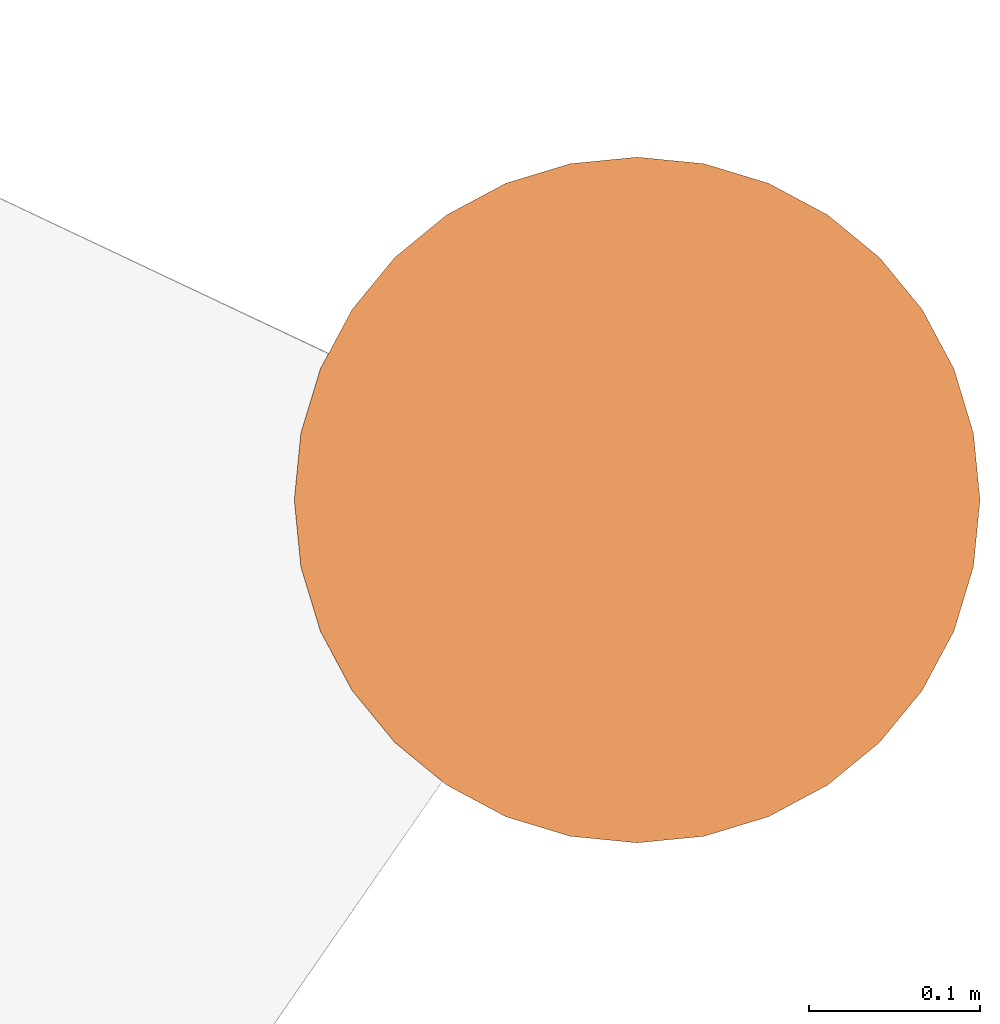
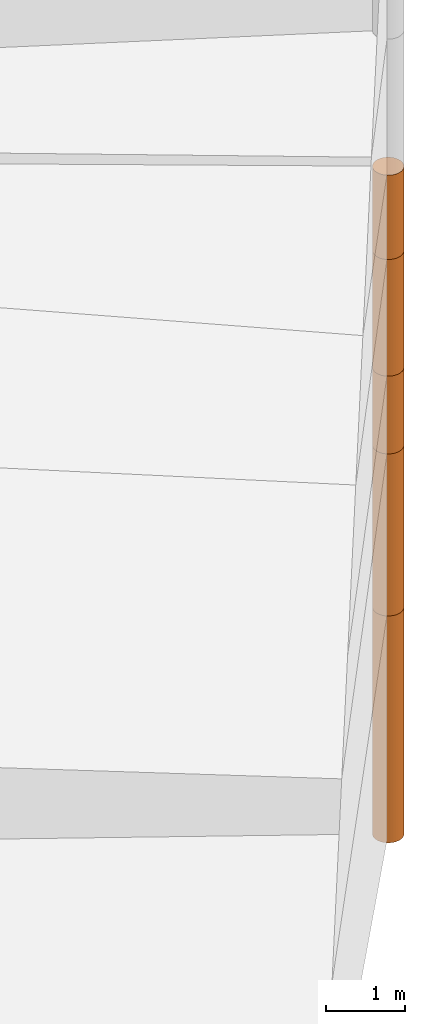
# One storey, part 21 of 24: 5 geographic elements.
"""IFC4 building model written with IfcOpenShell, lengths in metres."""

from ifc_helpers import new_model, entity, si_unit, converted_unit, frame, origin_with_axes, origin_2d_with_axis, place, context, subcontext, project, spatial, polygons, element, save


model = new_model("IFC4")

# Units and contexts
model_context = context("Model", 3, precision=1e-05, world=origin_with_axes())
plan_context = context("Plan", 2, precision=1e-05, world=origin_2d_with_axis())
body_context = subcontext(model_context, "Body", "Model", "MODEL_VIEW")
ifc_project = project(units=[converted_unit("PLANEANGLEUNIT", "degree", entity("IfcReal", 0.0174532925199433), si_unit("PLANEANGLEUNIT", "RADIAN"), dimensions=[0, 0, 0, 0, 0, 0, 0]), si_unit("AREAUNIT", "SQUARE_METRE"), si_unit("VOLUMEUNIT", "CUBIC_METRE"), si_unit("LENGTHUNIT", "METRE")], contexts=[model_context, plan_context])

# Site, building, storey
site_placement = place(None, origin_with_axes())
site = spatial("IfcSite", under=ifc_project, at=site_placement)
building_placement = place(site_placement, origin_with_axes())
building = spatial("IfcBuilding", under=site, at=building_placement, Name="Building")
storey_placement = place(building_placement, origin_with_axes())
storey = spatial("IfcBuildingStorey", under=building, at=storey_placement, Name="Storey")

# Geographic elements
geographic_element_1_placement = place(storey_placement, frame((50.0999984741211, 76.4000015258789, -11.7499990463257), z_axis=(0.0, 0.0, 1.0), x_axis=(1.0, 0.0, 0.0)))
element("IfcGeographicElement", 1, at=geographic_element_1_placement, inside=storey, PredefinedType="NOTDEFINED", context=body_context, shape_type="Tessellation", body=[
    polygons([(0.0, 0.0, -1.74999988079071), (0.0390180610120296, 0.196157038211823, -1.74999988079071), (0.0, 0.199999988079071, -1.74999988079071), (0.0, 0.0, 1.74999988079071), (0.0, 0.199999988079071, 1.74999988079071), (0.0390180610120296, 0.196157038211823, 1.74999988079071), (0.0765366926789284, 0.18477588891983, -1.74999988079071), (0.0765366926789284, 0.18477588891983, 1.74999988079071), (0.111114047467709, 0.166293919086456, -1.74999988079071), (0.111114047467709, 0.166293919086456, 1.74999988079071), (0.141421362757683, 0.141421362757683, -1.74999988079071), (0.141421362757683, 0.141421362757683, 1.74999988079071), (0.166293919086456, 0.111114047467709, -1.74999988079071), (0.166293919086456, 0.111114047467709, 1.74999988079071), (0.18477588891983, 0.0765366926789284, -1.74999988079071), (0.18477588891983, 0.0765366926789284, 1.74999988079071), (0.196157038211823, 0.0390180610120296, -1.74999988079071), (0.196157038211823, 0.0390180610120296, 1.74999988079071), (0.199999988079071, 0.0, -1.74999988079071), (0.199999988079071, 0.0, 1.74999988079071), (0.196157038211823, -0.0390180610120296, -1.74999988079071), (0.196157038211823, -0.0390180610120296, 1.74999988079071), (0.18477588891983, -0.0765366926789284, -1.74999988079071), (0.18477588891983, -0.0765366926789284, 1.74999988079071), (0.166293919086456, -0.111114047467709, -1.74999988079071), (0.166293919086456, -0.111114047467709, 1.74999988079071), (0.141421362757683, -0.141421362757683, -1.74999988079071), (0.141421362757683, -0.141421362757683, 1.74999988079071), (0.111114047467709, -0.166293919086456, -1.74999988079071), (0.111114047467709, -0.166293919086456, 1.74999988079071), (0.0765366926789284, -0.18477588891983, -1.74999988079071), (0.0765366926789284, -0.18477588891983, 1.74999988079071), (0.0390180610120296, -0.196157038211823, -1.74999988079071), (0.0390180610120296, -0.196157038211823, 1.74999988079071), (0.0, -0.199999988079071, -1.74999988079071), (0.0, -0.199999988079071, 1.74999988079071), (-0.0390180610120296, -0.196157038211823, -1.74999988079071), (-0.0390180610120296, -0.196157038211823, 1.74999988079071), (-0.0765366926789284, -0.18477588891983, -1.74999988079071), (-0.0765366926789284, -0.18477588891983, 1.74999988079071), (-0.111114047467709, -0.166293919086456, -1.74999988079071), (-0.111114047467709, -0.166293919086456, 1.74999988079071), (-0.141421362757683, -0.141421362757683, -1.74999988079071), (-0.141421362757683, -0.141421362757683, 1.74999988079071), (-0.166293919086456, -0.111114047467709, -1.74999988079071), (-0.166293919086456, -0.111114047467709, 1.74999988079071), (-0.18477588891983, -0.0765366926789284, -1.74999988079071), (-0.18477588891983, -0.0765366926789284, 1.74999988079071), (-0.196157038211823, -0.0390180610120296, -1.74999988079071), (-0.196157038211823, -0.0390180610120296, 1.74999988079071), (-0.199999988079071, 0.0, -1.74999988079071), (-0.199999988079071, 0.0, 1.74999988079071), (-0.196157038211823, 0.0390180610120296, -1.74999988079071), (-0.196157038211823, 0.0390180610120296, 1.74999988079071), (-0.18477588891983, 0.0765366926789284, -1.74999988079071), (-0.18477588891983, 0.0765366926789284, 1.74999988079071), (-0.166293919086456, 0.111114047467709, -1.74999988079071), (-0.166293919086456, 0.111114047467709, 1.74999988079071), (-0.141421362757683, 0.141421362757683, -1.74999988079071), (-0.141421362757683, 0.141421362757683, 1.74999988079071), (-0.111114047467709, 0.166293919086456, -1.74999988079071), (-0.111114047467709, 0.166293919086456, 1.74999988079071), (-0.0765366926789284, 0.18477588891983, -1.74999988079071), (-0.0765366926789284, 0.18477588891983, 1.74999988079071), (-0.0390180610120296, 0.196157038211823, -1.74999988079071), (-0.0390180610120296, 0.196157038211823, 1.74999988079071)], [[[3, 2, 1]], [[6, 5, 4]], [[28, 30, 29, 27]], [[2, 7, 1]], [[8, 6, 4]], [[64, 66, 65, 63]], [[7, 9, 1]], [[10, 8, 4]], [[9, 11, 1]], [[12, 10, 4]], [[6, 8, 7, 2]], [[1, 11, 13]], [[12, 4, 14]], [[66, 5, 3, 65]], [[1, 13, 15]], [[14, 4, 16]], [[12, 14, 13, 11]], [[1, 15, 17]], [[16, 4, 18]], [[14, 16, 15, 13]], [[1, 17, 19]], [[4, 20, 18]], [[16, 18, 17, 15]], [[1, 19, 21]], [[20, 4, 22]], [[18, 20, 19, 17]], [[1, 21, 23]], [[4, 24, 22]], [[20, 22, 21, 19]], [[1, 23, 25]], [[4, 26, 24]], [[22, 24, 23, 21]], [[27, 1, 25]], [[4, 28, 26]], [[24, 26, 25, 23]], [[1, 27, 29]], [[28, 4, 30]], [[26, 28, 27, 25]], [[1, 29, 31]], [[4, 32, 30]], [[5, 6, 2, 3]], [[1, 31, 33]], [[4, 34, 32]], [[30, 32, 31, 29]], [[1, 33, 35]], [[4, 36, 34]], [[8, 10, 9, 7]], [[1, 35, 37]], [[4, 38, 36]], [[32, 34, 33, 31]], [[1, 37, 39]], [[4, 40, 38]], [[36, 38, 37, 35]], [[1, 39, 41]], [[4, 42, 40]], [[38, 40, 39, 37]], [[43, 1, 41]], [[4, 44, 42]], [[40, 42, 41, 39]], [[43, 45, 1]], [[46, 44, 4]], [[42, 44, 43, 41]], [[45, 47, 1]], [[4, 48, 46]], [[44, 46, 45, 43]], [[47, 49, 1]], [[4, 50, 48]], [[46, 48, 47, 45]], [[51, 1, 49]], [[52, 50, 4]], [[48, 50, 49, 47]], [[51, 53, 1]], [[4, 54, 52]], [[50, 52, 51, 49]], [[55, 1, 53]], [[56, 54, 4]], [[52, 54, 53, 51]], [[57, 1, 55]], [[58, 56, 4]], [[54, 56, 55, 53]], [[57, 59, 1]], [[60, 58, 4]], [[56, 58, 57, 55]], [[59, 61, 1]], [[62, 60, 4]], [[58, 60, 59, 57]], [[61, 63, 1]], [[64, 62, 4]], [[60, 62, 61, 59]], [[63, 65, 1]], [[66, 64, 4]], [[62, 64, 63, 61]], [[65, 3, 1]], [[5, 66, 4]], [[34, 36, 35, 33]], [[10, 12, 11, 9]]]),
])
geographic_element_2_placement = place(storey_placement, frame((50.0999984741211, 76.4000015258789, -8.74999904632568), z_axis=(0.0, 0.0, 1.0), x_axis=(1.0, 0.0, 0.0)))
element("IfcGeographicElement", 2, at=geographic_element_2_placement, inside=storey, PredefinedType="NOTDEFINED", context=body_context, shape_type="Tessellation", body=[
    polygons([(0.0, 0.0, -1.24999988079071), (0.0390180610120296, 0.196157038211823, -1.24999988079071), (0.0, 0.199999988079071, -1.24999988079071), (0.0, 0.0, 1.24999988079071), (0.0, 0.199999988079071, 1.24999988079071), (0.0390180610120296, 0.196157038211823, 1.24999988079071), (0.0765366926789284, 0.18477588891983, -1.24999988079071), (0.0765366926789284, 0.18477588891983, 1.24999988079071), (0.111114047467709, 0.166293919086456, -1.24999988079071), (0.111114047467709, 0.166293919086456, 1.24999988079071), (0.141421362757683, 0.141421362757683, -1.24999988079071), (0.141421362757683, 0.141421362757683, 1.24999988079071), (0.166293919086456, 0.111114047467709, -1.24999988079071), (0.166293919086456, 0.111114047467709, 1.24999988079071), (0.18477588891983, 0.0765366926789284, -1.24999988079071), (0.18477588891983, 0.0765366926789284, 1.24999988079071), (0.196157038211823, 0.0390180610120296, -1.24999988079071), (0.196157038211823, 0.0390180610120296, 1.24999988079071), (0.199999988079071, 0.0, -1.24999988079071), (0.199999988079071, 0.0, 1.24999988079071), (0.196157038211823, -0.0390180610120296, -1.24999988079071), (0.196157038211823, -0.0390180610120296, 1.24999988079071), (0.18477588891983, -0.0765366926789284, -1.24999988079071), (0.18477588891983, -0.0765366926789284, 1.24999988079071), (0.166293919086456, -0.111114047467709, -1.24999988079071), (0.166293919086456, -0.111114047467709, 1.24999988079071), (0.141421362757683, -0.141421362757683, -1.24999988079071), (0.141421362757683, -0.141421362757683, 1.24999988079071), (0.111114047467709, -0.166293919086456, -1.24999988079071), (0.111114047467709, -0.166293919086456, 1.24999988079071), (0.0765366926789284, -0.18477588891983, -1.24999988079071), (0.0765366926789284, -0.18477588891983, 1.24999988079071), (0.0390180610120296, -0.196157038211823, -1.24999988079071), (0.0390180610120296, -0.196157038211823, 1.24999988079071), (0.0, -0.199999988079071, -1.24999988079071), (0.0, -0.199999988079071, 1.24999988079071), (-0.0390180610120296, -0.196157038211823, -1.24999988079071), (-0.0390180610120296, -0.196157038211823, 1.24999988079071), (-0.0765366926789284, -0.18477588891983, -1.24999988079071), (-0.0765366926789284, -0.18477588891983, 1.24999988079071), (-0.111114047467709, -0.166293919086456, -1.24999988079071), (-0.111114047467709, -0.166293919086456, 1.24999988079071), (-0.141421362757683, -0.141421362757683, -1.24999988079071), (-0.141421362757683, -0.141421362757683, 1.24999988079071), (-0.166293919086456, -0.111114047467709, -1.24999988079071), (-0.166293919086456, -0.111114047467709, 1.24999988079071), (-0.18477588891983, -0.0765366926789284, -1.24999988079071), (-0.18477588891983, -0.0765366926789284, 1.24999988079071), (-0.196157038211823, -0.0390180610120296, -1.24999988079071), (-0.196157038211823, -0.0390180610120296, 1.24999988079071), (-0.199999988079071, 0.0, -1.24999988079071), (-0.199999988079071, 0.0, 1.24999988079071), (-0.196157038211823, 0.0390180610120296, -1.24999988079071), (-0.196157038211823, 0.0390180610120296, 1.24999988079071), (-0.18477588891983, 0.0765366926789284, -1.24999988079071), (-0.18477588891983, 0.0765366926789284, 1.24999988079071), (-0.166293919086456, 0.111114047467709, -1.24999988079071), (-0.166293919086456, 0.111114047467709, 1.24999988079071), (-0.141421362757683, 0.141421362757683, -1.24999988079071), (-0.141421362757683, 0.141421362757683, 1.24999988079071), (-0.111114047467709, 0.166293919086456, -1.24999988079071), (-0.111114047467709, 0.166293919086456, 1.24999988079071), (-0.0765366926789284, 0.18477588891983, -1.24999988079071), (-0.0765366926789284, 0.18477588891983, 1.24999988079071), (-0.0390180610120296, 0.196157038211823, -1.24999988079071), (-0.0390180610120296, 0.196157038211823, 1.24999988079071)], [[[3, 2, 1]], [[6, 5, 4]], [[62, 64, 63, 61]], [[2, 7, 1]], [[8, 6, 4]], [[30, 32, 31, 29]], [[7, 9, 1]], [[10, 8, 4]], [[10, 12, 11, 9]], [[9, 11, 1]], [[12, 10, 4]], [[11, 13, 1]], [[12, 4, 14]], [[66, 5, 3, 65]], [[1, 13, 15]], [[4, 16, 14]], [[42, 44, 43, 41]], [[1, 15, 17]], [[16, 4, 18]], [[48, 50, 49, 47]], [[1, 17, 19]], [[4, 20, 18]], [[16, 18, 17, 15]], [[1, 19, 21]], [[4, 22, 20]], [[50, 52, 51, 49]], [[1, 21, 23]], [[22, 4, 24]], [[54, 56, 55, 53]], [[1, 23, 25]], [[4, 26, 24]], [[56, 58, 57, 55]], [[1, 25, 27]], [[26, 4, 28]], [[58, 60, 59, 57]], [[1, 27, 29]], [[28, 4, 30]], [[60, 62, 61, 59]], [[1, 29, 31]], [[4, 32, 30]], [[64, 66, 65, 63]], [[1, 31, 33]], [[4, 34, 32]], [[6, 8, 7, 2]], [[1, 33, 35]], [[4, 36, 34]], [[8, 10, 9, 7]], [[1, 35, 37]], [[4, 38, 36]], [[32, 34, 33, 31]], [[1, 37, 39]], [[4, 40, 38]], [[36, 38, 37, 35]], [[1, 39, 41]], [[4, 42, 40]], [[46, 48, 47, 45]], [[43, 1, 41]], [[4, 44, 42]], [[34, 36, 35, 33]], [[45, 1, 43]], [[4, 46, 44]], [[14, 16, 15, 13]], [[45, 47, 1]], [[48, 46, 4]], [[44, 46, 45, 43]], [[49, 1, 47]], [[4, 50, 48]], [[40, 42, 41, 39]], [[49, 51, 1]], [[52, 50, 4]], [[18, 20, 19, 17]], [[51, 53, 1]], [[54, 52, 4]], [[20, 22, 21, 19]], [[55, 1, 53]], [[4, 56, 54]], [[52, 54, 53, 51]], [[55, 57, 1]], [[58, 56, 4]], [[22, 24, 23, 21]], [[59, 1, 57]], [[60, 58, 4]], [[24, 26, 25, 23]], [[59, 61, 1]], [[62, 60, 4]], [[26, 28, 27, 25]], [[61, 63, 1]], [[64, 62, 4]], [[28, 30, 29, 27]], [[63, 65, 1]], [[66, 64, 4]], [[5, 6, 2, 3]], [[65, 3, 1]], [[5, 66, 4]], [[38, 40, 39, 37]], [[12, 14, 13, 11]]]),
])
geographic_element_3_placement = place(storey_placement, frame((50.0999984741211, 76.4000015258789, -6.89999914169312), z_axis=(0.0, 0.0, 1.0), x_axis=(1.0, 0.0, 0.0)))
element("IfcGeographicElement", 3, at=geographic_element_3_placement, inside=storey, PredefinedType="NOTDEFINED", context=body_context, shape_type="Tessellation", body=[
    polygons([(0.0, 0.0, -0.600000023841858), (0.0390180610120296, 0.196157038211823, -0.600000023841858), (0.0, 0.199999988079071, -0.600000023841858), (0.0, 0.0, 0.600000023841858), (0.0, 0.199999988079071, 0.600000023841858), (0.0390180610120296, 0.196157038211823, 0.600000023841858), (0.0765366926789284, 0.18477588891983, -0.600000023841858), (0.0765366926789284, 0.18477588891983, 0.600000023841858), (0.111114047467709, 0.166293919086456, -0.600000023841858), (0.111114047467709, 0.166293919086456, 0.600000023841858), (0.141421362757683, 0.141421362757683, -0.600000023841858), (0.141421362757683, 0.141421362757683, 0.600000023841858), (0.166293919086456, 0.111114047467709, -0.600000023841858), (0.166293919086456, 0.111114047467709, 0.600000023841858), (0.18477588891983, 0.0765366926789284, -0.600000023841858), (0.18477588891983, 0.0765366926789284, 0.600000023841858), (0.196157038211823, 0.0390180610120296, -0.600000023841858), (0.196157038211823, 0.0390180610120296, 0.600000023841858), (0.199999988079071, 0.0, -0.600000023841858), (0.199999988079071, 0.0, 0.600000023841858), (0.196157038211823, -0.0390180610120296, -0.600000023841858), (0.196157038211823, -0.0390180610120296, 0.600000023841858), (0.18477588891983, -0.0765366926789284, -0.600000023841858), (0.18477588891983, -0.0765366926789284, 0.600000023841858), (0.166293919086456, -0.111114047467709, -0.600000023841858), (0.166293919086456, -0.111114047467709, 0.600000023841858), (0.141421362757683, -0.141421362757683, -0.600000023841858), (0.141421362757683, -0.141421362757683, 0.600000023841858), (0.111114047467709, -0.166293919086456, -0.600000023841858), (0.111114047467709, -0.166293919086456, 0.600000023841858), (0.0765366926789284, -0.18477588891983, -0.600000023841858), (0.0765366926789284, -0.18477588891983, 0.600000023841858), (0.0390180610120296, -0.196157038211823, -0.600000023841858), (0.0390180610120296, -0.196157038211823, 0.600000023841858), (0.0, -0.199999988079071, -0.600000023841858), (0.0, -0.199999988079071, 0.600000023841858), (-0.0390180610120296, -0.196157038211823, -0.600000023841858), (-0.0390180610120296, -0.196157038211823, 0.600000023841858), (-0.0765366926789284, -0.18477588891983, -0.600000023841858), (-0.0765366926789284, -0.18477588891983, 0.600000023841858), (-0.111114047467709, -0.166293919086456, -0.600000023841858), (-0.111114047467709, -0.166293919086456, 0.600000023841858), (-0.141421362757683, -0.141421362757683, -0.600000023841858), (-0.141421362757683, -0.141421362757683, 0.600000023841858), (-0.166293919086456, -0.111114047467709, -0.600000023841858), (-0.166293919086456, -0.111114047467709, 0.600000023841858), (-0.18477588891983, -0.0765366926789284, -0.600000023841858), (-0.18477588891983, -0.0765366926789284, 0.600000023841858), (-0.196157038211823, -0.0390180610120296, -0.600000023841858), (-0.196157038211823, -0.0390180610120296, 0.600000023841858), (-0.199999988079071, 0.0, -0.600000023841858), (-0.199999988079071, 0.0, 0.600000023841858), (-0.196157038211823, 0.0390180610120296, -0.600000023841858), (-0.196157038211823, 0.0390180610120296, 0.600000023841858), (-0.18477588891983, 0.0765366926789284, -0.600000023841858), (-0.18477588891983, 0.0765366926789284, 0.600000023841858), (-0.166293919086456, 0.111114047467709, -0.600000023841858), (-0.166293919086456, 0.111114047467709, 0.600000023841858), (-0.141421362757683, 0.141421362757683, -0.600000023841858), (-0.141421362757683, 0.141421362757683, 0.600000023841858), (-0.111114047467709, 0.166293919086456, -0.600000023841858), (-0.111114047467709, 0.166293919086456, 0.600000023841858), (-0.0765366926789284, 0.18477588891983, -0.600000023841858), (-0.0765366926789284, 0.18477588891983, 0.600000023841858), (-0.0390180610120296, 0.196157038211823, -0.600000023841858), (-0.0390180610120296, 0.196157038211823, 0.600000023841858)], [[[3, 2, 1]], [[6, 5, 4]], [[28, 30, 29, 27]], [[2, 7, 1]], [[8, 6, 4]], [[36, 38, 37, 35]], [[7, 9, 1]], [[10, 8, 4]], [[56, 58, 57, 55]], [[9, 11, 1]], [[12, 10, 4]], [[58, 60, 59, 57]], [[11, 13, 1]], [[12, 4, 14]], [[54, 56, 55, 53]], [[1, 13, 15]], [[14, 4, 16]], [[10, 12, 11, 9]], [[1, 15, 17]], [[16, 4, 18]], [[60, 62, 61, 59]], [[1, 17, 19]], [[18, 4, 20]], [[16, 18, 17, 15]], [[1, 19, 21]], [[20, 4, 22]], [[18, 20, 19, 17]], [[1, 21, 23]], [[22, 4, 24]], [[20, 22, 21, 19]], [[1, 23, 25]], [[24, 4, 26]], [[22, 24, 23, 21]], [[27, 1, 25]], [[26, 4, 28]], [[24, 26, 25, 23]], [[1, 27, 29]], [[28, 4, 30]], [[62, 64, 63, 61]], [[1, 29, 31]], [[4, 32, 30]], [[64, 66, 65, 63]], [[1, 31, 33]], [[4, 34, 32]], [[30, 32, 31, 29]], [[1, 33, 35]], [[4, 36, 34]], [[8, 10, 9, 7]], [[1, 35, 37]], [[4, 38, 36]], [[32, 34, 33, 31]], [[1, 37, 39]], [[4, 40, 38]], [[6, 8, 7, 2]], [[1, 39, 41]], [[4, 42, 40]], [[38, 40, 39, 37]], [[43, 1, 41]], [[4, 44, 42]], [[40, 42, 41, 39]], [[45, 1, 43]], [[46, 44, 4]], [[42, 44, 43, 41]], [[47, 1, 45]], [[4, 48, 46]], [[44, 46, 45, 43]], [[49, 1, 47]], [[4, 50, 48]], [[46, 48, 47, 45]], [[51, 1, 49]], [[4, 52, 50]], [[48, 50, 49, 47]], [[53, 1, 51]], [[4, 54, 52]], [[66, 5, 3, 65]], [[55, 1, 53]], [[4, 56, 54]], [[52, 54, 53, 51]], [[57, 1, 55]], [[4, 58, 56]], [[57, 59, 1]], [[60, 58, 4]], [[34, 36, 35, 33]], [[59, 61, 1]], [[62, 60, 4]], [[14, 16, 15, 13]], [[61, 63, 1]], [[64, 62, 4]], [[26, 28, 27, 25]], [[63, 65, 1]], [[66, 64, 4]], [[5, 6, 2, 3]], [[65, 3, 1]], [[5, 66, 4]], [[50, 52, 51, 49]], [[12, 14, 13, 11]]]),
])
geographic_element_4_placement = place(storey_placement, frame((50.0999984741211, 76.4000015258789, -5.39999914169312), z_axis=(0.0, 0.0, 1.0), x_axis=(1.0, 0.0, 0.0)))
element("IfcGeographicElement", 4, at=geographic_element_4_placement, inside=storey, PredefinedType="NOTDEFINED", context=body_context, shape_type="Tessellation", body=[
    polygons([(0.0, 0.0, -0.899999916553497), (0.0390180610120296, 0.196157038211823, -0.899999916553497), (0.0, 0.199999988079071, -0.899999916553497), (0.0, 0.0, 0.899999916553497), (0.0, 0.199999988079071, 0.899999916553497), (0.0390180610120296, 0.196157038211823, 0.899999916553497), (0.0765366926789284, 0.18477588891983, -0.899999916553497), (0.0765366926789284, 0.18477588891983, 0.899999916553497), (0.111114047467709, 0.166293919086456, -0.899999916553497), (0.111114047467709, 0.166293919086456, 0.899999916553497), (0.141421362757683, 0.141421362757683, -0.899999916553497), (0.141421362757683, 0.141421362757683, 0.899999916553497), (0.166293919086456, 0.111114047467709, -0.899999916553497), (0.166293919086456, 0.111114047467709, 0.899999916553497), (0.18477588891983, 0.0765366926789284, -0.899999916553497), (0.18477588891983, 0.0765366926789284, 0.899999916553497), (0.196157038211823, 0.0390180610120296, -0.899999916553497), (0.196157038211823, 0.0390180610120296, 0.899999916553497), (0.199999988079071, 0.0, -0.899999916553497), (0.199999988079071, 0.0, 0.899999916553497), (0.196157038211823, -0.0390180610120296, -0.899999916553497), (0.196157038211823, -0.0390180610120296, 0.899999916553497), (0.18477588891983, -0.0765366926789284, -0.899999916553497), (0.18477588891983, -0.0765366926789284, 0.899999916553497), (0.166293919086456, -0.111114047467709, -0.899999916553497), (0.166293919086456, -0.111114047467709, 0.899999916553497), (0.141421362757683, -0.141421362757683, -0.899999916553497), (0.141421362757683, -0.141421362757683, 0.899999916553497), (0.111114047467709, -0.166293919086456, -0.899999916553497), (0.111114047467709, -0.166293919086456, 0.899999916553497), (0.0765366926789284, -0.18477588891983, -0.899999916553497), (0.0765366926789284, -0.18477588891983, 0.899999916553497), (0.0390180610120296, -0.196157038211823, -0.899999916553497), (0.0390180610120296, -0.196157038211823, 0.899999916553497), (0.0, -0.199999988079071, -0.899999916553497), (0.0, -0.199999988079071, 0.899999916553497), (-0.0390180610120296, -0.196157038211823, -0.899999916553497), (-0.0390180610120296, -0.196157038211823, 0.899999916553497), (-0.0765366926789284, -0.18477588891983, -0.899999916553497), (-0.0765366926789284, -0.18477588891983, 0.899999916553497), (-0.111114047467709, -0.166293919086456, -0.899999916553497), (-0.111114047467709, -0.166293919086456, 0.899999916553497), (-0.141421362757683, -0.141421362757683, -0.899999916553497), (-0.141421362757683, -0.141421362757683, 0.899999916553497), (-0.166293919086456, -0.111114047467709, -0.899999916553497), (-0.166293919086456, -0.111114047467709, 0.899999916553497), (-0.18477588891983, -0.0765366926789284, -0.899999916553497), (-0.18477588891983, -0.0765366926789284, 0.899999916553497), (-0.196157038211823, -0.0390180610120296, -0.899999916553497), (-0.196157038211823, -0.0390180610120296, 0.899999916553497), (-0.199999988079071, 0.0, -0.899999916553497), (-0.199999988079071, 0.0, 0.899999916553497), (-0.196157038211823, 0.0390180610120296, -0.899999916553497), (-0.196157038211823, 0.0390180610120296, 0.899999916553497), (-0.18477588891983, 0.0765366926789284, -0.899999916553497), (-0.18477588891983, 0.0765366926789284, 0.899999916553497), (-0.166293919086456, 0.111114047467709, -0.899999916553497), (-0.166293919086456, 0.111114047467709, 0.899999916553497), (-0.141421362757683, 0.141421362757683, -0.899999916553497), (-0.141421362757683, 0.141421362757683, 0.899999916553497), (-0.111114047467709, 0.166293919086456, -0.899999916553497), (-0.111114047467709, 0.166293919086456, 0.899999916553497), (-0.0765366926789284, 0.18477588891983, -0.899999916553497), (-0.0765366926789284, 0.18477588891983, 0.899999916553497), (-0.0390180610120296, 0.196157038211823, -0.899999916553497), (-0.0390180610120296, 0.196157038211823, 0.899999916553497)], [[[3, 2, 1]], [[6, 5, 4]], [[32, 34, 33, 31]], [[2, 7, 1]], [[8, 6, 4]], [[64, 66, 65, 63]], [[7, 9, 1]], [[10, 8, 4]], [[9, 11, 1]], [[12, 10, 4]], [[40, 42, 41, 39]], [[1, 11, 13]], [[12, 4, 14]], [[10, 12, 11, 9]], [[1, 13, 15]], [[4, 16, 14]], [[12, 14, 13, 11]], [[1, 15, 17]], [[16, 4, 18]], [[18, 20, 19, 17]], [[1, 17, 19]], [[4, 20, 18]], [[20, 22, 21, 19]], [[1, 19, 21]], [[4, 22, 20]], [[22, 24, 23, 21]], [[1, 21, 23]], [[22, 4, 24]], [[54, 56, 55, 53]], [[1, 23, 25]], [[4, 26, 24]], [[56, 58, 57, 55]], [[1, 25, 27]], [[4, 28, 26]], [[24, 26, 25, 23]], [[1, 27, 29]], [[28, 4, 30]], [[26, 28, 27, 25]], [[1, 29, 31]], [[4, 32, 30]], [[46, 48, 47, 45]], [[1, 31, 33]], [[4, 34, 32]], [[36, 38, 37, 35]], [[1, 33, 35]], [[4, 36, 34]], [[42, 44, 43, 41]], [[1, 35, 37]], [[4, 38, 36]], [[38, 40, 39, 37]], [[1, 37, 39]], [[4, 40, 38]], [[34, 36, 35, 33]], [[1, 39, 41]], [[4, 42, 40]], [[8, 10, 9, 7]], [[43, 1, 41]], [[4, 44, 42]], [[44, 46, 45, 43]], [[43, 45, 1]], [[4, 46, 44]], [[30, 32, 31, 29]], [[45, 47, 1]], [[48, 46, 4]], [[28, 30, 29, 27]], [[49, 1, 47]], [[4, 50, 48]], [[5, 6, 2, 3]], [[49, 51, 1]], [[52, 50, 4]], [[48, 50, 49, 47]], [[51, 53, 1]], [[54, 52, 4]], [[50, 52, 51, 49]], [[55, 1, 53]], [[4, 56, 54]], [[52, 54, 53, 51]], [[55, 57, 1]], [[58, 56, 4]], [[58, 60, 59, 57]], [[59, 1, 57]], [[60, 58, 4]], [[60, 62, 61, 59]], [[59, 61, 1]], [[62, 60, 4]], [[62, 64, 63, 61]], [[61, 63, 1]], [[64, 62, 4]], [[14, 16, 15, 13]], [[63, 65, 1]], [[66, 64, 4]], [[16, 18, 17, 15]], [[65, 3, 1]], [[5, 66, 4]], [[6, 8, 7, 2]], [[66, 5, 3, 65]]]),
])
geographic_element_5_placement = place(storey_placement, frame((50.0999984741211, 76.4000015258789, -3.84999895095825), z_axis=(0.0, 0.0, 1.0), x_axis=(1.0, 0.0, 0.0)))
element("IfcGeographicElement", 5, at=geographic_element_5_placement, inside=storey, PredefinedType="NOTDEFINED", context=body_context, shape_type="Tessellation", body=[
    polygons([(0.0, 0.0, -0.649999916553497), (0.0390180610120296, 0.196157038211823, -0.649999916553497), (0.0, 0.199999988079071, -0.649999916553497), (0.0, 0.0, 0.649999916553497), (0.0, 0.199999988079071, 0.649999916553497), (0.0390180610120296, 0.196157038211823, 0.649999916553497), (0.0765366926789284, 0.18477588891983, -0.649999916553497), (0.0765366926789284, 0.18477588891983, 0.649999916553497), (0.111114047467709, 0.166293919086456, -0.649999916553497), (0.111114047467709, 0.166293919086456, 0.649999916553497), (0.141421362757683, 0.141421362757683, -0.649999916553497), (0.141421362757683, 0.141421362757683, 0.649999916553497), (0.166293919086456, 0.111114047467709, -0.649999916553497), (0.166293919086456, 0.111114047467709, 0.649999916553497), (0.18477588891983, 0.0765366926789284, -0.649999916553497), (0.18477588891983, 0.0765366926789284, 0.649999916553497), (0.196157038211823, 0.0390180610120296, -0.649999916553497), (0.196157038211823, 0.0390180610120296, 0.649999916553497), (0.199999988079071, 0.0, -0.649999916553497), (0.199999988079071, 0.0, 0.649999916553497), (0.196157038211823, -0.0390180610120296, -0.649999916553497), (0.196157038211823, -0.0390180610120296, 0.649999916553497), (0.18477588891983, -0.0765366926789284, -0.649999916553497), (0.18477588891983, -0.0765366926789284, 0.649999916553497), (0.166293919086456, -0.111114047467709, -0.649999916553497), (0.166293919086456, -0.111114047467709, 0.649999916553497), (0.141421362757683, -0.141421362757683, -0.649999916553497), (0.141421362757683, -0.141421362757683, 0.649999916553497), (0.111114047467709, -0.166293919086456, -0.649999916553497), (0.111114047467709, -0.166293919086456, 0.649999916553497), (0.0765366926789284, -0.18477588891983, -0.649999916553497), (0.0765366926789284, -0.18477588891983, 0.649999916553497), (0.0390180610120296, -0.196157038211823, -0.649999916553497), (0.0390180610120296, -0.196157038211823, 0.649999916553497), (0.0, -0.199999988079071, -0.649999916553497), (0.0, -0.199999988079071, 0.649999916553497), (-0.0390180610120296, -0.196157038211823, -0.649999916553497), (-0.0390180610120296, -0.196157038211823, 0.649999916553497), (-0.0765366926789284, -0.18477588891983, -0.649999916553497), (-0.0765366926789284, -0.18477588891983, 0.649999916553497), (-0.111114047467709, -0.166293919086456, -0.649999916553497), (-0.111114047467709, -0.166293919086456, 0.649999916553497), (-0.141421362757683, -0.141421362757683, -0.649999916553497), (-0.141421362757683, -0.141421362757683, 0.649999916553497), (-0.166293919086456, -0.111114047467709, -0.649999916553497), (-0.166293919086456, -0.111114047467709, 0.649999916553497), (-0.18477588891983, -0.0765366926789284, -0.649999916553497), (-0.18477588891983, -0.0765366926789284, 0.649999916553497), (-0.196157038211823, -0.0390180610120296, -0.649999916553497), (-0.196157038211823, -0.0390180610120296, 0.649999916553497), (-0.199999988079071, 0.0, -0.649999916553497), (-0.199999988079071, 0.0, 0.649999916553497), (-0.196157038211823, 0.0390180610120296, -0.649999916553497), (-0.196157038211823, 0.0390180610120296, 0.649999916553497), (-0.18477588891983, 0.0765366926789284, -0.649999916553497), (-0.18477588891983, 0.0765366926789284, 0.649999916553497), (-0.166293919086456, 0.111114047467709, -0.649999916553497), (-0.166293919086456, 0.111114047467709, 0.649999916553497), (-0.141421362757683, 0.141421362757683, -0.649999916553497), (-0.141421362757683, 0.141421362757683, 0.649999916553497), (-0.111114047467709, 0.166293919086456, -0.649999916553497), (-0.111114047467709, 0.166293919086456, 0.649999916553497), (-0.0765366926789284, 0.18477588891983, -0.649999916553497), (-0.0765366926789284, 0.18477588891983, 0.649999916553497), (-0.0390180610120296, 0.196157038211823, -0.649999916553497), (-0.0390180610120296, 0.196157038211823, 0.649999916553497)], [[[3, 2, 1]], [[6, 5, 4]], [[32, 34, 33, 31]], [[2, 7, 1]], [[8, 6, 4]], [[64, 66, 65, 63]], [[7, 9, 1]], [[10, 8, 4]], [[9, 11, 1]], [[12, 10, 4]], [[40, 42, 41, 39]], [[1, 11, 13]], [[12, 4, 14]], [[10, 12, 11, 9]], [[1, 13, 15]], [[4, 16, 14]], [[12, 14, 13, 11]], [[1, 15, 17]], [[4, 18, 16]], [[18, 20, 19, 17]], [[1, 17, 19]], [[4, 20, 18]], [[20, 22, 21, 19]], [[1, 19, 21]], [[4, 22, 20]], [[22, 24, 23, 21]], [[1, 21, 23]], [[22, 4, 24]], [[54, 56, 55, 53]], [[1, 23, 25]], [[24, 4, 26]], [[56, 58, 57, 55]], [[1, 25, 27]], [[4, 28, 26]], [[24, 26, 25, 23]], [[1, 27, 29]], [[28, 4, 30]], [[26, 28, 27, 25]], [[1, 29, 31]], [[4, 32, 30]], [[46, 48, 47, 45]], [[1, 31, 33]], [[4, 34, 32]], [[36, 38, 37, 35]], [[1, 33, 35]], [[4, 36, 34]], [[42, 44, 43, 41]], [[1, 35, 37]], [[4, 38, 36]], [[38, 40, 39, 37]], [[1, 37, 39]], [[4, 40, 38]], [[34, 36, 35, 33]], [[1, 39, 41]], [[4, 42, 40]], [[8, 10, 9, 7]], [[43, 1, 41]], [[4, 44, 42]], [[44, 46, 45, 43]], [[43, 45, 1]], [[4, 46, 44]], [[30, 32, 31, 29]], [[47, 1, 45]], [[48, 46, 4]], [[28, 30, 29, 27]], [[49, 1, 47]], [[50, 48, 4]], [[5, 6, 2, 3]], [[49, 51, 1]], [[52, 50, 4]], [[48, 50, 49, 47]], [[51, 53, 1]], [[54, 52, 4]], [[50, 52, 51, 49]], [[53, 55, 1]], [[4, 56, 54]], [[52, 54, 53, 51]], [[55, 57, 1]], [[4, 58, 56]], [[58, 60, 59, 57]], [[59, 1, 57]], [[60, 58, 4]], [[60, 62, 61, 59]], [[59, 61, 1]], [[62, 60, 4]], [[62, 64, 63, 61]], [[61, 63, 1]], [[64, 62, 4]], [[14, 16, 15, 13]], [[63, 65, 1]], [[66, 64, 4]], [[16, 18, 17, 15]], [[65, 3, 1]], [[5, 66, 4]], [[6, 8, 7, 2]], [[66, 5, 3, 65]]]),
])

save(model, "model.ifc")
